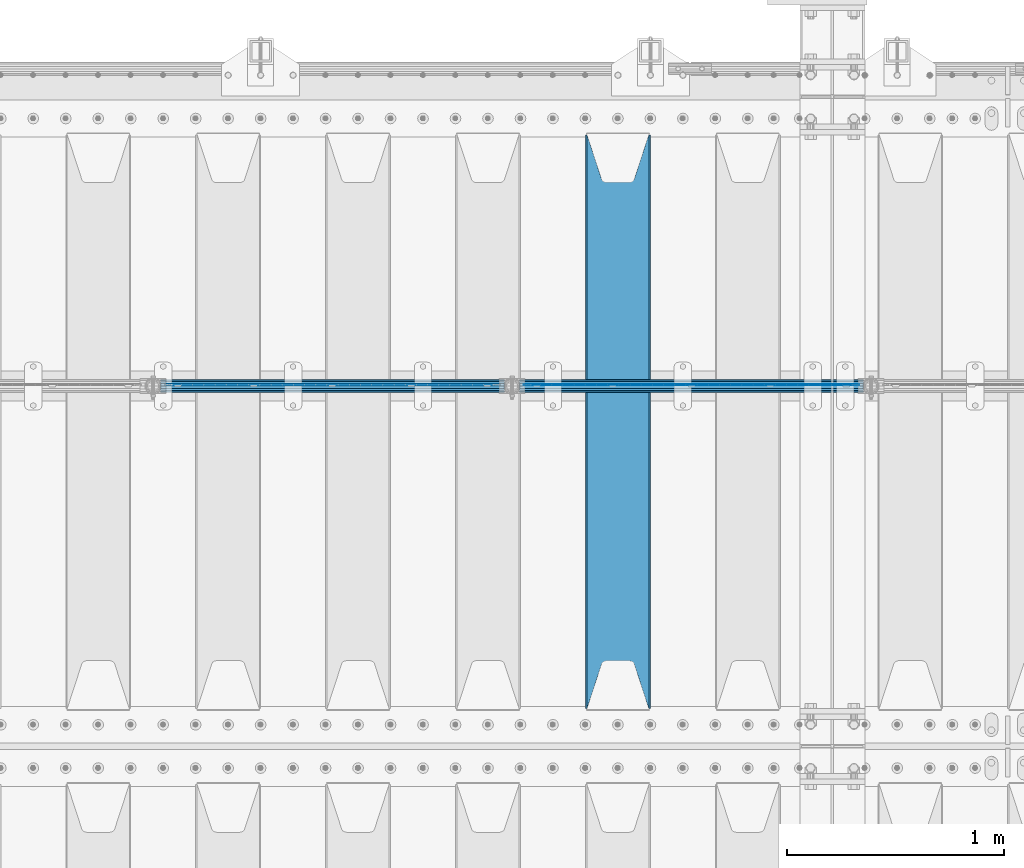
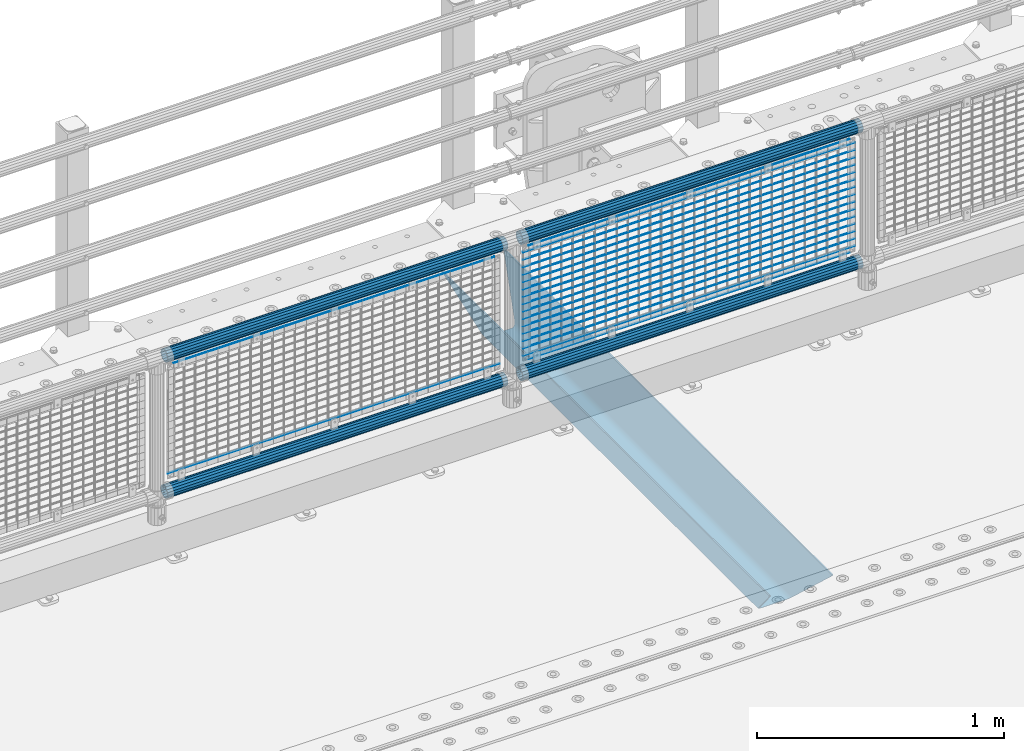
# One storey, part 98 of 193: 24 beams.
"""IFC2X3 building model written with IfcOpenShell, lengths in millimetres."""

from ifc_helpers import new_model, si_unit, frame, origin_with_axes, place, context, subcontext, project, spatial, faceted_brep, material, type_object, element, save


model = new_model("IFC2X3")

# Units and contexts
model_context = context("Model", 3, precision=1e-05, world=origin_with_axes())
body_context = subcontext(model_context, "Body", "Model", "MODEL_VIEW")
ifc_project = project(units=[si_unit("LENGTHUNIT", "METRE", prefix="MILLI"), si_unit("AREAUNIT", "SQUARE_METRE"), si_unit("VOLUMEUNIT", "CUBIC_METRE"), si_unit("MASSUNIT", "GRAM", prefix="KILO"), si_unit("TIMEUNIT", "SECOND"), si_unit("PLANEANGLEUNIT", "RADIAN"), si_unit("SOLIDANGLEUNIT", "STERADIAN"), si_unit("THERMODYNAMICTEMPERATUREUNIT", "DEGREE_CELSIUS"), si_unit("LUMINOUSINTENSITYUNIT", "LUMEN")], contexts=[model_context])

# Site, building, storey
site_placement = place(None, origin_with_axes())
site = spatial("IfcSite", under=ifc_project, at=site_placement, CompositionType="ELEMENT")
building_placement = place(site_placement, origin_with_axes())
building = spatial("IfcBuilding", under=site, at=building_placement, Name="Standard", CompositionType="ELEMENT")
storey_placement = place(building_placement, origin_with_axes())
storey = spatial("IfcBuildingStorey", under=building, at=storey_placement, Name="Undefined", CompositionType="ELEMENT", Elevation=0.0)

# Beams
ifc_material_1 = material(Name="STEEL/S355N")
beam_type_1 = type_object("IfcBeamType", PredefinedType="NOTDEFINED")
beam_1_placement = place(storey_placement, frame((-33050.0, 27175.0, -115.0), z_axis=(0.0, 0.0, 1.0), x_axis=(0.0, 1.0, 0.0)))
element("IfcBeam", 1, at=beam_1_placement, inside=storey, type_object=beam_type_1, material=ifc_material_1, context=body_context, shape_type="Brep", body=[
    faceted_brep([(0.0, 150.0, 115.0), (0.0, 143.689999999999, 115.0), (2650.00000000297, 143.689999999999, 115.0), (2650.00000000297, 150.0, 115.0), (2650.00000000297, 142.059565218398, 110.000000003094), (2650.00000000297, 148.3695652184, 110.000000003094), (2441.90079219209, -80.1103600731112, -98.0992078077845), (2437.7588105432, -77.5672621345584, -102.241189456673), (2434.06523489747, -74.4080125315522, -105.934765102404), (2430.9108609509, -70.710272125576, -109.089139048974), (2428.37322971128, -66.5649389910068, -111.626770288588), (2426.51472138055, -62.0739139532889, -113.485278619323), (2425.38102192092, -57.3475956567672, -114.618978078955), (2424.99999999988, -52.5021667386536, -115.0), (2424.99999999988, 52.5021667386536, -115.0), (2425.38102192092, 57.3475956567672, -114.618978078955), (2426.51472138055, 62.0739139532889, -113.485278619323), (2428.37322971128, 66.5649389910068, -111.626770288588), (2430.9108609509, 70.710272125576, -109.089139048974), (2434.06523489747, 74.4080125315522, -105.934765102404), (2437.7588105432, 77.5672621345584, -102.241189456673), (2441.90079219209, 80.1103600731112, -98.0992078077846), (2446.38936140512, 81.9747917625791, -93.6106385947584), (2448.2494850041, 76.2713538057251, -91.7505149957729), (2444.62967112263, 74.76777986261, -95.3703288772456), (2441.28936334127, 72.7168944282894, -98.710636658607), (2438.31067330439, 70.1691124903846, -101.689326695487), (2435.76682334748, 67.1870637758839, -104.233176652398), (2433.72034654134, 63.8440531834895, -106.279653458539), (2432.22154950042, 60.222258798236, -107.778450499454), (2431.30727574265, 56.4107117849089, -108.692724257221), (2430.99999999987, 52.5031078186876, -109.0), (2430.99999999987, -52.5031078186876, -109.0), (2431.30727574265, -56.4107117849089, -108.692724257221), (2432.22154950042, -60.222258798236, -107.778450499454), (2433.72034654134, -63.8440531834895, -106.279653458539), (2435.76682334748, -67.1870637758839, -104.233176652398), (2438.31067330439, -70.1691124903846, -101.689326695487), (2441.28936334127, -72.7168944282894, -98.7106366586071), (2444.62967112263, -74.76777986261, -95.3703288772457), (2448.2494850041, -76.2713538057251, -91.7505149957729), (2650.00000000297, -142.059565218398, 110.000000003094), (2650.00000000297, -148.3695652184, 110.000000003094), (2446.38936140512, -81.9747917625791, -93.6106385947584), (2650.00000000297, -143.689999999999, 115.0), (2650.00000000297, -150.0, 115.0), (0.0, -143.689999999999, 115.0), (0.0, -150.0, 115.0), (0.0, -148.369565218261, 110.000000002667), (203.610638597427, -81.9747917625791, -93.6106385947584), (208.099207810446, -80.1103600731112, -98.0992078077845), (212.241189459342, -77.5672621345584, -102.241189456673), (215.93476510507, -74.4080125315522, -105.934765102404), (219.089139051641, -70.710272125576, -109.089139048974), (221.626770291256, -66.5649389910068, -111.626770288588), (223.485278621989, -62.0739139532889, -113.485278619323), (224.618978081624, -57.3475956567672, -114.618978078955), (225.000000002663, -52.5021667386536, -115.0), (225.000000002663, 52.5021667386536, -115.0), (224.618978081624, 57.3475956567672, -114.618978078955), (223.485278621989, 62.0739139532889, -113.485278619323), (221.626770291256, 66.5649389910068, -111.626770288588), (219.089139051641, 70.710272125576, -109.089139048974), (215.93476510507, 74.4080125315522, -105.934765102404), (212.241189459342, 77.5672621345584, -102.241189456673), (208.099207810446, 80.1103600731112, -98.0992078077846), (203.610638597427, 81.9747917625791, -93.6106385947584), (0.0, 148.369565218261, 110.000000002667), (0.0, 142.05956521826, 110.000000002667), (201.750514998439, 76.2713538057251, -91.7505149957729), (205.370328879915, 74.76777986261, -95.3703288772456), (208.710636661275, 72.7168944282894, -98.710636658607), (211.689326698157, 70.1691124903846, -101.689326695487), (214.233176655063, 67.1870637758839, -104.233176652398), (216.279653461206, 63.8440531834895, -106.279653458539), (217.778450502123, 60.222258798236, -107.778450499454), (218.69272425989, 56.4107117849089, -108.692724257221), (219.00000000267, 52.5031078186876, -109.0), (219.00000000267, -52.5031078186876, -109.0), (218.69272425989, -56.4107117849089, -108.692724257221), (217.778450502123, -60.222258798236, -107.778450499454), (216.279653461206, -63.8440531834895, -106.279653458539), (214.233176655063, -67.1870637758839, -104.233176652398), (211.689326698157, -70.1691124903846, -101.689326695487), (208.710636661275, -72.7168944282894, -98.7106366586071), (205.370328879915, -74.76777986261, -95.3703288772457), (201.750514998439, -76.2713538057251, -91.7505149957729), (0.0, -142.05956521826, 110.000000002667)], [[[0, 1, 2, 3]], [[3, 2, 4, 5]], [[6, 7, 8, 9, 10, 11, 12, 13, 14, 15, 16, 17, 18, 19, 20, 21, 22, 5, 4, 23, 24, 25, 26, 27, 28, 29, 30, 31, 32, 33, 34, 35, 36, 37, 38, 39, 40, 41, 42, 43]], [[44, 45, 42, 41]], [[46, 47, 45, 44]], [[43, 42, 45, 47, 48, 49]], [[6, 43, 49, 50]], [[7, 6, 50, 51]], [[8, 7, 51, 52]], [[9, 8, 52, 53]], [[10, 9, 53, 54]], [[11, 10, 54, 55]], [[12, 11, 55, 56]], [[13, 12, 56, 57]], [[14, 13, 57, 58]], [[15, 14, 58, 59]], [[16, 15, 59, 60]], [[17, 16, 60, 61]], [[18, 17, 61, 62]], [[19, 18, 62, 63]], [[20, 19, 63, 64]], [[21, 20, 64, 65]], [[22, 21, 65, 66]], [[0, 3, 5, 22, 66, 67]], [[1, 0, 67, 68]], [[23, 4, 2, 1, 68, 69]], [[24, 23, 69, 70]], [[25, 24, 70, 71]], [[26, 25, 71, 72]], [[27, 26, 72, 73]], [[28, 27, 73, 74]], [[29, 28, 74, 75]], [[30, 29, 75, 76]], [[31, 30, 76, 77]], [[32, 31, 77, 78]], [[33, 32, 78, 79]], [[34, 33, 79, 80]], [[35, 34, 80, 81]], [[36, 35, 81, 82]], [[37, 36, 82, 83]], [[38, 37, 83, 84]], [[39, 38, 84, 85]], [[40, 39, 85, 86]], [[46, 44, 41, 40, 86, 87]], [[47, 46, 87, 48]], [[86, 85, 84, 83, 82, 81, 80, 79, 78, 77, 76, 75, 74, 73, 72, 71, 70, 69, 68, 67, 66, 65, 64, 63, 62, 61, 60, 59, 58, 57, 56, 55, 54, 53, 52, 51, 50, 49, 48, 87]]]),
])
ifc_material_2 = material(Name="Misc_Undefined")
beam_type_2 = type_object("IfcBeamType", Name="D3", PredefinedType="NOTDEFINED")
for number, where, z_axis, x_axis in (
    (2, (-33484.0, 28670.5, 851.597000000001), (0.0, 0.0, 1.0), (1.0, 0.0, 0.0)),
    (3, (-33484.0, 28670.5, 669.452000000001), (0.0, 0.0, 1.0), (1.0, 0.0, 0.0)),
    (4, (-33484.0, 28670.5, 523.736000000001), (0.0, 0.0, 1.0), (1.0, 0.0, 0.0)),
    (5, (-33484.0, 28670.5, 487.307000000001), (0.0, 0.0, 1.0), (1.0, 0.0, 0.0)),
    (6, (-33484.0, 28670.5, 705.881000000001), (0.0, 0.0, 1.0), (1.0, 0.0, 0.0)),
    (7, (-33484.0, 28670.5, 596.594000000001), (0.0, 0.0, 1.0), (1.0, 0.0, 0.0)),
    (8, (-33484.0, 28670.5, 450.878000000001), (0.0, 0.0, 1.0), (1.0, 0.0, 0.0)),
    (9, (-33484.0, 28670.5, 815.168000000001), (0.0, 0.0, 1.0), (1.0, 0.0, 0.0)),
    (10, (-33484.0, 28670.5, 888.026000000001), (0.0, 0.0, 1.0), (1.0, 0.0, 0.0)),
    (11, (-33484.0, 28670.5, 778.739000000001), (0.0, 0.0, 1.0), (1.0, 0.0, 0.0)),
    (12, (-33484.0, 28670.5, 742.310000000001), (0.0, 0.0, 1.0), (1.0, 0.0, 0.0)),
    (13, (-33484.0, 28670.5, 633.023000000001), (0.0, 0.0, 1.0), (1.0, 0.0, 0.0)),
    (14, (-33484.0, 28670.5, 560.165000000001), (0.0, 0.0, 1.0), (1.0, 0.0, 0.0)),
    (15, (-33484.0, 28670.5, 414.449000000001), (0.0, 0.0, 1.0), (1.0, 0.0, 0.0)),
):
    element("IfcBeam", number, at=place(storey_placement, frame(where, z_axis=z_axis, x_axis=x_axis)), inside=storey, type_object=beam_type_2, material=ifc_material_2, ObjectType="D3", context=body_context, shape_type="Brep", body=[
        faceted_brep([(0.0, -1.49999999999636, 3.63797880709171e-12), (0.0, -0.75, -1.29903810567669), (1548.0, -0.75, -1.29903810567669), (1548.0, -1.5, 0.0), (0.0, 0.75, -1.29903810567669), (1548.0, 0.75, -1.29903810567669), (0.0, 1.50000000000364, 7.27595761418343e-12), (1548.0, 1.5, 0.0), (0.0, 0.75, 1.29903810567669), (1548.0, 0.75, 1.29903810567669), (0.0, -0.75, 1.29903810567669), (1548.0, -0.75, 1.29903810567669)], [[[0, 1, 2, 3]], [[1, 4, 5, 2]], [[4, 6, 7, 5]], [[6, 8, 9, 7]], [[8, 10, 11, 9]], [[10, 0, 3, 11]], [[5, 7, 9, 11, 3, 2]], [[10, 8, 6, 4, 1, 0]]]),
    ])
beam_2_placement = place(storey_placement, frame((-33459.0, 28670.5, 353.020000000001), z_axis=(0.0, 0.0, 1.0), x_axis=(1.0, 0.0, 0.0)))
element("IfcBeam", 16, at=beam_2_placement, inside=storey, type_object=beam_type_2, material=ifc_material_2, ObjectType="D3", context=body_context, shape_type="Brep", body=[
    faceted_brep([(0.0, -1.49999999999636, 3.63797880709171e-12), (0.0, -0.75, -1.29903810567669), (1498.0, -0.75, -1.29903810567669), (1498.0, -1.5, 0.0), (0.0, 0.75, -1.29903810567669), (1498.0, 0.75, -1.29903810567663), (0.0, 1.50000000000364, 7.27595761418343e-12), (1498.0, 1.5, 0.0), (0.0, 0.75, 1.29903810567669), (1498.0, 0.75, 1.29903810567669), (0.0, -0.75, 1.29903810567669), (1498.0, -0.75, 1.29903810567669)], [[[0, 1, 2, 3]], [[1, 4, 5, 2]], [[4, 6, 7, 5]], [[6, 8, 9, 7]], [[8, 10, 11, 9]], [[10, 0, 3, 11]], [[5, 7, 9, 11, 3, 2]], [[10, 8, 6, 4, 1, 0]]]),
])
beam_3_placement = place(storey_placement, frame((-33484.0, 28670.5, 378.020000000001), z_axis=(0.0, 0.0, 1.0), x_axis=(1.0, 0.0, 0.0)))
element("IfcBeam", 17, at=beam_3_placement, inside=storey, type_object=beam_type_2, material=ifc_material_2, ObjectType="D3", context=body_context, shape_type="Brep", body=[
    faceted_brep([(0.0, -1.49999999999636, 3.63797880709171e-12), (0.0, -0.75, -1.29903810567669), (1548.0, -0.75, -1.29903810567669), (1548.0, -1.5, 0.0), (0.0, 0.75, -1.29903810567669), (1548.0, 0.75, -1.29903810567669), (0.0, 1.50000000000364, 7.27595761418343e-12), (1548.0, 1.5, 0.0), (0.0, 0.75, 1.29903810567669), (1548.0, 0.75, 1.29903810567669), (0.0, -0.75, 1.29903810567669), (1548.0, -0.75, 1.29903810567669)], [[[0, 1, 2, 3]], [[1, 4, 5, 2]], [[4, 6, 7, 5]], [[6, 8, 9, 7]], [[8, 10, 11, 9]], [[10, 0, 3, 11]], [[5, 7, 9, 11, 3, 2]], [[10, 8, 6, 4, 1, 0]]]),
])
beam_4_placement = place(storey_placement, frame((-33459.0, 28670.5, 913.020000000001), z_axis=(0.0, 0.0, 1.0), x_axis=(1.0, 0.0, 0.0)))
element("IfcBeam", 18, at=beam_4_placement, inside=storey, type_object=beam_type_2, material=ifc_material_2, ObjectType="D3", context=body_context, shape_type="Brep", body=[
    faceted_brep([(0.0, -1.49999999999636, 3.63797880709171e-12), (0.0, -0.75, -1.29903810567669), (1498.0, -0.75, -1.29903810567669), (1498.0, -1.5, 0.0), (0.0, 0.75, -1.29903810567669), (1498.0, 0.75, -1.29903810567663), (0.0, 1.50000000000364, 7.27595761418343e-12), (1498.0, 1.5, 0.0), (0.0, 0.75, 1.29903810567669), (1498.0, 0.75, 1.29903810567669), (0.0, -0.75, 1.29903810567669), (1498.0, -0.75, 1.29903810567669)], [[[0, 1, 2, 3]], [[1, 4, 5, 2]], [[4, 6, 7, 5]], [[6, 8, 9, 7]], [[8, 10, 11, 9]], [[10, 0, 3, 11]], [[5, 7, 9, 11, 3, 2]], [[10, 8, 6, 4, 1, 0]]]),
])
beam_5_placement = place(storey_placement, frame((-35142.0, 28670.5, 378.020000000001), z_axis=(0.0, 0.0, 1.0), x_axis=(1.0, 0.0, 0.0)))
element("IfcBeam", 19, at=beam_5_placement, inside=storey, type_object=beam_type_2, material=ifc_material_2, ObjectType="D3", context=body_context, shape_type="Brep", body=[
    faceted_brep([(0.0, -1.49999999999636, 3.63797880709171e-12), (0.0, -0.75, -1.29903810567669), (1548.0, -0.75, -1.29903810567669), (1548.0, -1.5, 0.0), (0.0, 0.75, -1.29903810567669), (1548.0, 0.75, -1.29903810567669), (0.0, 1.50000000000364, 7.27595761418343e-12), (1548.0, 1.5, 0.0), (0.0, 0.75, 1.29903810567669), (1548.0, 0.75, 1.29903810567669), (0.0, -0.75, 1.29903810567669), (1548.0, -0.75, 1.29903810567669)], [[[0, 1, 2, 3]], [[1, 4, 5, 2]], [[4, 6, 7, 5]], [[6, 8, 9, 7]], [[8, 10, 11, 9]], [[10, 0, 3, 11]], [[5, 7, 9, 11, 3, 2]], [[10, 8, 6, 4, 1, 0]]]),
])
beam_6_placement = place(storey_placement, frame((-35117.0, 28670.5, 913.020000000001), z_axis=(0.0, 0.0, 1.0), x_axis=(1.0, 0.0, 0.0)))
element("IfcBeam", 20, at=beam_6_placement, inside=storey, type_object=beam_type_2, material=ifc_material_2, ObjectType="D3", context=body_context, shape_type="Brep", body=[
    faceted_brep([(0.0, -1.49999999999636, 3.63797880709171e-12), (0.0, -0.75, -1.29903810567669), (1498.0, -0.75, -1.29903810567669), (1498.0, -1.5, 0.0), (0.0, 0.75, -1.29903810567669), (1498.0, 0.75, -1.29903810567663), (0.0, 1.50000000000364, 7.27595761418343e-12), (1498.0, 1.5, 0.0), (0.0, 0.75, 1.29903810567669), (1498.0, 0.75, 1.29903810567669), (0.0, -0.75, 1.29903810567669), (1498.0, -0.75, 1.29903810567669)], [[[0, 1, 2, 3]], [[1, 4, 5, 2]], [[4, 6, 7, 5]], [[6, 8, 9, 7]], [[8, 10, 11, 9]], [[10, 0, 3, 11]], [[5, 7, 9, 11, 3, 2]], [[10, 8, 6, 4, 1, 0]]]),
])
ifc_material_3 = material()
beam_type_3 = type_object("IfcBeamType", PredefinedType="NOTDEFINED")
beam_7_placement = place(storey_placement, frame((-33504.15, 28664.5, 969.850000000001), z_axis=(0.0, 0.0, 1.0), x_axis=(1.0, 0.0, 0.0)))
element("IfcBeam", 21, at=beam_7_placement, inside=storey, type_object=beam_type_3, material=ifc_material_3, context=body_context, shape_type="Brep", body=[
    faceted_brep([(0.0, -25.3499999999985, 0.0), (0.0, -23.4203461491597, 9.70102501045403), (1588.0, -23.4203461491597, 9.70102501045506), (1588.0, -25.3499999999985, 0.0), (0.0, -17.9251569030785, 17.9251569030785), (1588.0, -17.9251569030785, 17.925156903079), (0.0, -9.70102501045403, 23.4203461491597), (1588.0, -9.70102501045403, 23.4203461491611), (0.0, 0.0, 25.3499999999985), (1588.0, 0.0, 25.35), (0.0, 9.70102501045403, 23.4203461491597), (1588.0, 9.70102501045403, 23.4203461491611), (0.0, 17.9251569030785, 17.9251569030785), (1588.0, 17.9251569030785, 17.925156903079), (0.0, 23.4203461491597, 9.70102501045403), (1588.0, 23.4203461491597, 9.70102501045506), (0.0, 25.3499999999985, 0.0), (1588.0, 25.3499999999985, 0.0), (0.0, 23.4203461491597, -9.70102501045403), (1588.0, 23.4203461491597, -9.70102501045506), (0.0, 17.9251569030785, -17.9251569030785), (1588.0, 17.9251569030785, -17.925156903079), (0.0, 9.70102501045403, -23.4203461491597), (1588.0, 9.70102501045403, -23.4203461491611), (0.0, 0.0, -25.3499999999985), (1588.0, 0.0, -25.35), (0.0, -9.70102501045403, -23.4203461491597), (1588.0, -9.70102501045403, -23.4203461491611), (0.0, -17.9251569030785, -17.9251569030785), (1588.0, -17.9251569030785, -17.925156903079), (0.0, -23.4203461491597, -9.70102501045403), (1588.0, -23.4203461491597, -9.70102501045506), (0.0, -30.1500000000015, 0.0), (0.0, -27.8549679052157, -11.5379054858058), (1588.0, -27.8549679052157, -11.5379054858075), (1588.0, -30.1500000000015, 0.0), (0.0, -21.3192694527752, -21.3192694527752), (1588.0, -21.3192694527752, -21.3192694527744), (0.0, -11.5379054858058, -27.8549679052157), (1588.0, -11.5379054858058, -27.8549679052153), (0.0, 0.0, -30.1500000000015), (1588.0, 0.0, -30.15), (0.0, 11.5379054858058, -27.8549679052157), (1588.0, 11.5379054858058, -27.8549679052153), (0.0, 21.3192694527752, -21.3192694527752), (1588.0, 21.3192694527752, -21.3192694527744), (0.0, 27.8549679052157, -11.5379054858058), (1588.0, 27.8549679052157, -11.5379054858074), (0.0, 30.1500000000015, 0.0), (1588.0, 30.1500000000015, 0.0), (0.0, 27.8549679052157, 11.5379054858058), (1588.0, 27.8549679052157, 11.5379054858074), (0.0, 21.3192694527752, 21.3192694527752), (1588.0, 21.3192694527752, 21.3192694527744), (0.0, 11.5379054858058, 27.8549679052157), (1588.0, 11.5379054858058, 27.8549679052153), (0.0, 0.0, 30.1500000000015), (1588.0, 0.0, 30.15), (0.0, -11.5379054858058, 27.8549679052157), (1588.0, -11.5379054858058, 27.8549679052153), (0.0, -21.3192694527752, 21.3192694527752), (1588.0, -21.3192694527752, 21.3192694527744), (0.0, -27.8549679052157, 11.5379054858058), (1588.0, -27.8549679052157, 11.5379054858074)], [[[0, 1, 2, 3]], [[1, 4, 5, 2]], [[4, 6, 7, 5]], [[6, 8, 9, 7]], [[8, 10, 11, 9]], [[10, 12, 13, 11]], [[12, 14, 15, 13]], [[14, 16, 17, 15]], [[16, 18, 19, 17]], [[18, 20, 21, 19]], [[20, 22, 23, 21]], [[22, 24, 25, 23]], [[24, 26, 27, 25]], [[26, 28, 29, 27]], [[28, 30, 31, 29]], [[30, 0, 3, 31]], [[32, 33, 34, 35]], [[33, 36, 37, 34]], [[36, 38, 39, 37]], [[38, 40, 41, 39]], [[40, 42, 43, 41]], [[42, 44, 45, 43]], [[44, 46, 47, 45]], [[46, 48, 49, 47]], [[48, 50, 51, 49]], [[50, 52, 53, 51]], [[52, 54, 55, 53]], [[54, 56, 57, 55]], [[56, 58, 59, 57]], [[58, 60, 61, 59]], [[60, 62, 63, 61]], [[62, 32, 35, 63]], [[37, 39, 41, 43, 45, 47, 49, 51, 53, 55, 57, 59, 61, 63, 35, 34], [5, 7, 9, 11, 13, 15, 17, 19, 21, 23, 25, 27, 29, 31, 3, 2]], [[62, 60, 58, 56, 54, 52, 50, 48, 46, 44, 42, 40, 38, 36, 33, 32], [30, 28, 26, 24, 22, 20, 18, 16, 14, 12, 10, 8, 6, 4, 1, 0]]]),
])
beam_8_placement = place(storey_placement, frame((-33504.15, 28664.5, 298.170000000002), z_axis=(0.0, 0.0, 1.0), x_axis=(1.0, 0.0, 0.0)))
element("IfcBeam", 22, at=beam_8_placement, inside=storey, type_object=beam_type_3, material=ifc_material_3, context=body_context, shape_type="Brep", body=[
    faceted_brep([(0.0, -25.3499999999985, 0.0), (0.0, -23.4203461491597, 9.70102501045403), (1588.0, -23.4203461491597, 9.70102501045506), (1588.0, -25.3499999999985, 0.0), (0.0, -17.9251569030785, 17.9251569030785), (1588.0, -17.9251569030785, 17.925156903079), (0.0, -9.70102501045403, 23.4203461491597), (1588.0, -9.70102501045403, 23.4203461491611), (0.0, 0.0, 25.3499999999985), (1588.0, 0.0, 25.35), (0.0, 9.70102501045403, 23.4203461491597), (1588.0, 9.70102501045403, 23.4203461491611), (0.0, 17.9251569030785, 17.9251569030785), (1588.0, 17.9251569030785, 17.925156903079), (0.0, 23.4203461491597, 9.70102501045403), (1588.0, 23.4203461491597, 9.70102501045506), (0.0, 25.3499999999985, 0.0), (1588.0, 25.3499999999985, 0.0), (0.0, 23.4203461491597, -9.70102501045403), (1588.0, 23.4203461491597, -9.70102501045506), (0.0, 17.9251569030785, -17.9251569030785), (1588.0, 17.9251569030785, -17.925156903079), (0.0, 9.70102501045403, -23.4203461491597), (1588.0, 9.70102501045403, -23.4203461491611), (0.0, 0.0, -25.3499999999985), (1588.0, 0.0, -25.35), (0.0, -9.70102501045403, -23.4203461491597), (1588.0, -9.70102501045403, -23.4203461491611), (0.0, -17.9251569030785, -17.9251569030785), (1588.0, -17.9251569030785, -17.925156903079), (0.0, -23.4203461491597, -9.70102501045403), (1588.0, -23.4203461491597, -9.70102501045506), (0.0, -30.1500000000015, 0.0), (0.0, -27.8549679052157, -11.5379054858058), (1588.0, -27.8549679052157, -11.5379054858075), (1588.0, -30.1500000000015, 0.0), (0.0, -21.3192694527752, -21.3192694527752), (1588.0, -21.3192694527752, -21.3192694527744), (0.0, -11.5379054858058, -27.8549679052157), (1588.0, -11.5379054858058, -27.8549679052153), (0.0, 0.0, -30.1500000000015), (1588.0, 0.0, -30.15), (0.0, 11.5379054858058, -27.8549679052157), (1588.0, 11.5379054858058, -27.8549679052153), (0.0, 21.3192694527752, -21.3192694527752), (1588.0, 21.3192694527752, -21.3192694527744), (0.0, 27.8549679052157, -11.5379054858058), (1588.0, 27.8549679052157, -11.5379054858074), (0.0, 30.1500000000015, 0.0), (1588.0, 30.1500000000015, 0.0), (0.0, 27.8549679052157, 11.5379054858058), (1588.0, 27.8549679052157, 11.5379054858074), (0.0, 21.3192694527752, 21.3192694527752), (1588.0, 21.3192694527752, 21.3192694527744), (0.0, 11.5379054858058, 27.8549679052157), (1588.0, 11.5379054858058, 27.8549679052153), (0.0, 0.0, 30.1500000000015), (1588.0, 0.0, 30.15), (0.0, -11.5379054858058, 27.8549679052157), (1588.0, -11.5379054858058, 27.8549679052153), (0.0, -21.3192694527752, 21.3192694527752), (1588.0, -21.3192694527752, 21.3192694527744), (0.0, -27.8549679052157, 11.5379054858058), (1588.0, -27.8549679052157, 11.5379054858074)], [[[0, 1, 2, 3]], [[1, 4, 5, 2]], [[4, 6, 7, 5]], [[6, 8, 9, 7]], [[8, 10, 11, 9]], [[10, 12, 13, 11]], [[12, 14, 15, 13]], [[14, 16, 17, 15]], [[16, 18, 19, 17]], [[18, 20, 21, 19]], [[20, 22, 23, 21]], [[22, 24, 25, 23]], [[24, 26, 27, 25]], [[26, 28, 29, 27]], [[28, 30, 31, 29]], [[30, 0, 3, 31]], [[32, 33, 34, 35]], [[33, 36, 37, 34]], [[36, 38, 39, 37]], [[38, 40, 41, 39]], [[40, 42, 43, 41]], [[42, 44, 45, 43]], [[44, 46, 47, 45]], [[46, 48, 49, 47]], [[48, 50, 51, 49]], [[50, 52, 53, 51]], [[52, 54, 55, 53]], [[54, 56, 57, 55]], [[56, 58, 59, 57]], [[58, 60, 61, 59]], [[60, 62, 63, 61]], [[62, 32, 35, 63]], [[37, 39, 41, 43, 45, 47, 49, 51, 53, 55, 57, 59, 61, 63, 35, 34], [5, 7, 9, 11, 13, 15, 17, 19, 21, 23, 25, 27, 29, 31, 3, 2]], [[62, 60, 58, 56, 54, 52, 50, 48, 46, 44, 42, 40, 38, 36, 33, 32], [30, 28, 26, 24, 22, 20, 18, 16, 14, 12, 10, 8, 6, 4, 1, 0]]]),
])
beam_9_placement = place(storey_placement, frame((-35162.15, 28664.5, 969.850000000001), z_axis=(0.0, 0.0, 1.0), x_axis=(1.0, 0.0, 0.0)))
element("IfcBeam", 23, at=beam_9_placement, inside=storey, type_object=beam_type_3, material=ifc_material_3, context=body_context, shape_type="Brep", body=[
    faceted_brep([(0.0, -25.3499999999985, 0.0), (0.0, -23.4203461491597, 9.70102501045403), (1588.0, -23.4203461491597, 9.70102501045506), (1588.0, -25.3499999999985, 0.0), (0.0, -17.9251569030785, 17.9251569030785), (1588.0, -17.9251569030785, 17.925156903079), (0.0, -9.70102501045403, 23.4203461491597), (1588.0, -9.70102501045403, 23.4203461491611), (0.0, 0.0, 25.3499999999985), (1588.0, 0.0, 25.35), (0.0, 9.70102501045403, 23.4203461491597), (1588.0, 9.70102501045403, 23.4203461491611), (0.0, 17.9251569030785, 17.9251569030785), (1588.0, 17.9251569030785, 17.925156903079), (0.0, 23.4203461491597, 9.70102501045403), (1588.0, 23.4203461491597, 9.70102501045506), (0.0, 25.3499999999985, 0.0), (1588.0, 25.3499999999985, 0.0), (0.0, 23.4203461491597, -9.70102501045403), (1588.0, 23.4203461491597, -9.70102501045506), (0.0, 17.9251569030785, -17.9251569030785), (1588.0, 17.9251569030785, -17.925156903079), (0.0, 9.70102501045403, -23.4203461491597), (1588.0, 9.70102501045403, -23.4203461491611), (0.0, 0.0, -25.3499999999985), (1588.0, 0.0, -25.35), (0.0, -9.70102501045403, -23.4203461491597), (1588.0, -9.70102501045403, -23.4203461491611), (0.0, -17.9251569030785, -17.9251569030785), (1588.0, -17.9251569030785, -17.925156903079), (0.0, -23.4203461491597, -9.70102501045403), (1588.0, -23.4203461491597, -9.70102501045506), (0.0, -30.1500000000015, 0.0), (0.0, -27.8549679052157, -11.5379054858058), (1588.0, -27.8549679052157, -11.5379054858075), (1588.0, -30.1500000000015, 0.0), (0.0, -21.3192694527752, -21.3192694527752), (1588.0, -21.3192694527752, -21.3192694527744), (0.0, -11.5379054858058, -27.8549679052157), (1588.0, -11.5379054858058, -27.8549679052153), (0.0, 0.0, -30.1500000000015), (1588.0, 0.0, -30.15), (0.0, 11.5379054858058, -27.8549679052157), (1588.0, 11.5379054858058, -27.8549679052153), (0.0, 21.3192694527752, -21.3192694527752), (1588.0, 21.3192694527752, -21.3192694527744), (0.0, 27.8549679052157, -11.5379054858058), (1588.0, 27.8549679052157, -11.5379054858074), (0.0, 30.1500000000015, 0.0), (1588.0, 30.1500000000015, 0.0), (0.0, 27.8549679052157, 11.5379054858058), (1588.0, 27.8549679052157, 11.5379054858074), (0.0, 21.3192694527752, 21.3192694527752), (1588.0, 21.3192694527752, 21.3192694527744), (0.0, 11.5379054858058, 27.8549679052157), (1588.0, 11.5379054858058, 27.8549679052153), (0.0, 0.0, 30.1500000000015), (1588.0, 0.0, 30.15), (0.0, -11.5379054858058, 27.8549679052157), (1588.0, -11.5379054858058, 27.8549679052153), (0.0, -21.3192694527752, 21.3192694527752), (1588.0, -21.3192694527752, 21.3192694527744), (0.0, -27.8549679052157, 11.5379054858058), (1588.0, -27.8549679052157, 11.5379054858074)], [[[0, 1, 2, 3]], [[1, 4, 5, 2]], [[4, 6, 7, 5]], [[6, 8, 9, 7]], [[8, 10, 11, 9]], [[10, 12, 13, 11]], [[12, 14, 15, 13]], [[14, 16, 17, 15]], [[16, 18, 19, 17]], [[18, 20, 21, 19]], [[20, 22, 23, 21]], [[22, 24, 25, 23]], [[24, 26, 27, 25]], [[26, 28, 29, 27]], [[28, 30, 31, 29]], [[30, 0, 3, 31]], [[32, 33, 34, 35]], [[33, 36, 37, 34]], [[36, 38, 39, 37]], [[38, 40, 41, 39]], [[40, 42, 43, 41]], [[42, 44, 45, 43]], [[44, 46, 47, 45]], [[46, 48, 49, 47]], [[48, 50, 51, 49]], [[50, 52, 53, 51]], [[52, 54, 55, 53]], [[54, 56, 57, 55]], [[56, 58, 59, 57]], [[58, 60, 61, 59]], [[60, 62, 63, 61]], [[62, 32, 35, 63]], [[37, 39, 41, 43, 45, 47, 49, 51, 53, 55, 57, 59, 61, 63, 35, 34], [5, 7, 9, 11, 13, 15, 17, 19, 21, 23, 25, 27, 29, 31, 3, 2]], [[62, 60, 58, 56, 54, 52, 50, 48, 46, 44, 42, 40, 38, 36, 33, 32], [30, 28, 26, 24, 22, 20, 18, 16, 14, 12, 10, 8, 6, 4, 1, 0]]]),
])
beam_10_placement = place(storey_placement, frame((-35162.15, 28664.5, 298.170000000002), z_axis=(0.0, 0.0, 1.0), x_axis=(1.0, 0.0, 0.0)))
element("IfcBeam", 24, at=beam_10_placement, inside=storey, type_object=beam_type_3, material=ifc_material_3, context=body_context, shape_type="Brep", body=[
    faceted_brep([(0.0, -25.3499999999985, 0.0), (0.0, -23.4203461491597, 9.70102501045403), (1588.0, -23.4203461491597, 9.70102501045506), (1588.0, -25.3499999999985, 0.0), (0.0, -17.9251569030785, 17.9251569030785), (1588.0, -17.9251569030785, 17.925156903079), (0.0, -9.70102501045403, 23.4203461491597), (1588.0, -9.70102501045403, 23.4203461491611), (0.0, 0.0, 25.3499999999985), (1588.0, 0.0, 25.35), (0.0, 9.70102501045403, 23.4203461491597), (1588.0, 9.70102501045403, 23.4203461491611), (0.0, 17.9251569030785, 17.9251569030785), (1588.0, 17.9251569030785, 17.925156903079), (0.0, 23.4203461491597, 9.70102501045403), (1588.0, 23.4203461491597, 9.70102501045506), (0.0, 25.3499999999985, 0.0), (1588.0, 25.3499999999985, 0.0), (0.0, 23.4203461491597, -9.70102501045403), (1588.0, 23.4203461491597, -9.70102501045506), (0.0, 17.9251569030785, -17.9251569030785), (1588.0, 17.9251569030785, -17.925156903079), (0.0, 9.70102501045403, -23.4203461491597), (1588.0, 9.70102501045403, -23.4203461491611), (0.0, 0.0, -25.3499999999985), (1588.0, 0.0, -25.35), (0.0, -9.70102501045403, -23.4203461491597), (1588.0, -9.70102501045403, -23.4203461491611), (0.0, -17.9251569030785, -17.9251569030785), (1588.0, -17.9251569030785, -17.925156903079), (0.0, -23.4203461491597, -9.70102501045403), (1588.0, -23.4203461491597, -9.70102501045506), (0.0, -30.1500000000015, 0.0), (0.0, -27.8549679052157, -11.5379054858058), (1588.0, -27.8549679052157, -11.5379054858075), (1588.0, -30.1500000000015, 0.0), (0.0, -21.3192694527752, -21.3192694527752), (1588.0, -21.3192694527752, -21.3192694527744), (0.0, -11.5379054858058, -27.8549679052157), (1588.0, -11.5379054858058, -27.8549679052153), (0.0, 0.0, -30.1500000000015), (1588.0, 0.0, -30.15), (0.0, 11.5379054858058, -27.8549679052157), (1588.0, 11.5379054858058, -27.8549679052153), (0.0, 21.3192694527752, -21.3192694527752), (1588.0, 21.3192694527752, -21.3192694527744), (0.0, 27.8549679052157, -11.5379054858058), (1588.0, 27.8549679052157, -11.5379054858074), (0.0, 30.1500000000015, 0.0), (1588.0, 30.1500000000015, 0.0), (0.0, 27.8549679052157, 11.5379054858058), (1588.0, 27.8549679052157, 11.5379054858074), (0.0, 21.3192694527752, 21.3192694527752), (1588.0, 21.3192694527752, 21.3192694527744), (0.0, 11.5379054858058, 27.8549679052157), (1588.0, 11.5379054858058, 27.8549679052153), (0.0, 0.0, 30.1500000000015), (1588.0, 0.0, 30.15), (0.0, -11.5379054858058, 27.8549679052157), (1588.0, -11.5379054858058, 27.8549679052153), (0.0, -21.3192694527752, 21.3192694527752), (1588.0, -21.3192694527752, 21.3192694527744), (0.0, -27.8549679052157, 11.5379054858058), (1588.0, -27.8549679052157, 11.5379054858074)], [[[0, 1, 2, 3]], [[1, 4, 5, 2]], [[4, 6, 7, 5]], [[6, 8, 9, 7]], [[8, 10, 11, 9]], [[10, 12, 13, 11]], [[12, 14, 15, 13]], [[14, 16, 17, 15]], [[16, 18, 19, 17]], [[18, 20, 21, 19]], [[20, 22, 23, 21]], [[22, 24, 25, 23]], [[24, 26, 27, 25]], [[26, 28, 29, 27]], [[28, 30, 31, 29]], [[30, 0, 3, 31]], [[32, 33, 34, 35]], [[33, 36, 37, 34]], [[36, 38, 39, 37]], [[38, 40, 41, 39]], [[40, 42, 43, 41]], [[42, 44, 45, 43]], [[44, 46, 47, 45]], [[46, 48, 49, 47]], [[48, 50, 51, 49]], [[50, 52, 53, 51]], [[52, 54, 55, 53]], [[54, 56, 57, 55]], [[56, 58, 59, 57]], [[58, 60, 61, 59]], [[60, 62, 63, 61]], [[62, 32, 35, 63]], [[37, 39, 41, 43, 45, 47, 49, 51, 53, 55, 57, 59, 61, 63, 35, 34], [5, 7, 9, 11, 13, 15, 17, 19, 21, 23, 25, 27, 29, 31, 3, 2]], [[62, 60, 58, 56, 54, 52, 50, 48, 46, 44, 42, 40, 38, 36, 33, 32], [30, 28, 26, 24, 22, 20, 18, 16, 14, 12, 10, 8, 6, 4, 1, 0]]]),
])

save(model, "model.ifc")
